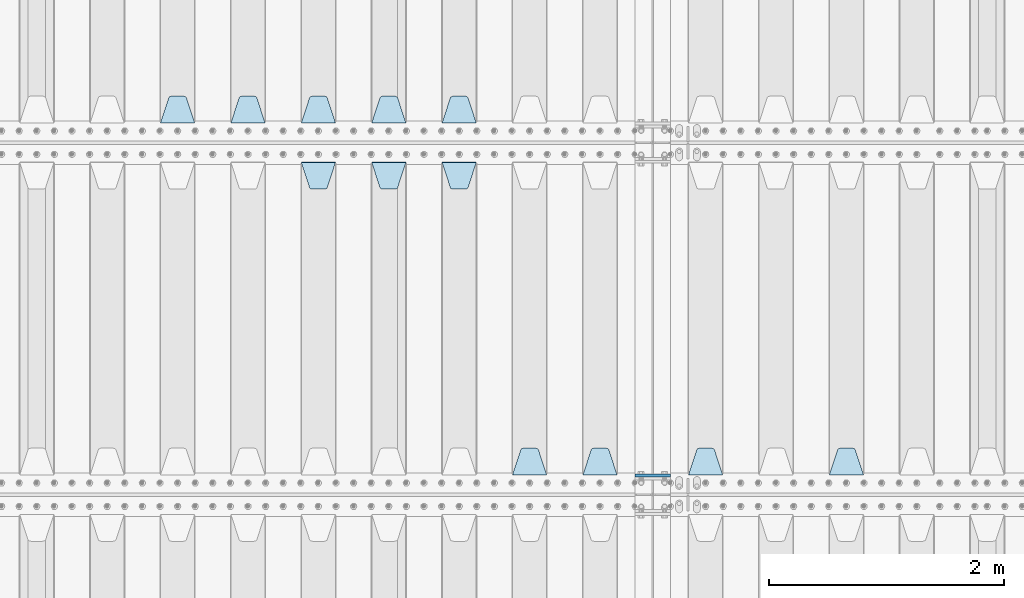
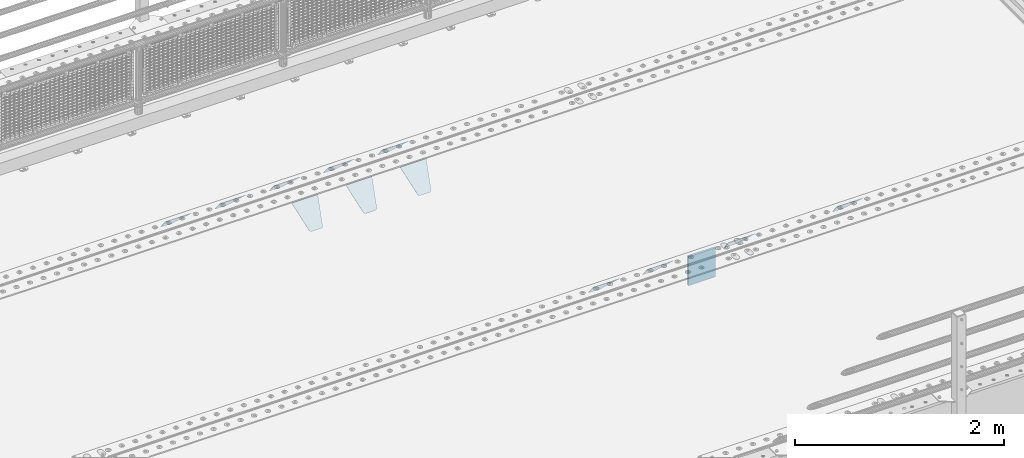
# One storey, part 209 of 247: 13 plates.
"""IFC2X3 building model written with IfcOpenShell, lengths in millimetres."""

from ifc_helpers import new_model, si_unit, frame, origin_with_axes, place, context, subcontext, project, spatial, faceted_brep, material, type_object, element, save


model = new_model("IFC2X3")

# Units and contexts
model_context = context("Model", 3, precision=1e-05, world=origin_with_axes())
body_context = subcontext(model_context, "Body", "Model", "MODEL_VIEW")
ifc_project = project(units=[si_unit("LENGTHUNIT", "METRE", prefix="MILLI"), si_unit("AREAUNIT", "SQUARE_METRE"), si_unit("VOLUMEUNIT", "CUBIC_METRE"), si_unit("MASSUNIT", "GRAM", prefix="KILO"), si_unit("TIMEUNIT", "SECOND"), si_unit("PLANEANGLEUNIT", "RADIAN"), si_unit("SOLIDANGLEUNIT", "STERADIAN"), si_unit("THERMODYNAMICTEMPERATUREUNIT", "DEGREE_CELSIUS"), si_unit("LUMINOUSINTENSITYUNIT", "LUMEN")], contexts=[model_context])

# Site, building, storey
site_placement = place(None, origin_with_axes())
site = spatial("IfcSite", under=ifc_project, at=site_placement, CompositionType="ELEMENT")
building_placement = place(site_placement, origin_with_axes())
building = spatial("IfcBuilding", under=site, at=building_placement, Name="Standard", CompositionType="ELEMENT")
storey_placement = place(building_placement, origin_with_axes())
storey = spatial("IfcBuildingStorey", under=building, at=storey_placement, Name="Undefined", CompositionType="ELEMENT", Elevation=0.0)

# Plates
ifc_material = material(Name="STEEL/S355N")
plate_type_1 = type_object("IfcPlateType", PredefinedType="NOTDEFINED")
plate_1_placement = place(storey_placement, frame((12100.0, 3162.5, -340.000000000044), z_axis=(0.0, 0.0, 1.0), x_axis=(1.0, 0.0, 0.0)))
element("IfcPlate", 1, at=plate_1_placement, inside=storey, type_object=plate_type_1, material=ifc_material, context=body_context, shape_type="Brep", body=[
    faceted_brep([(0.0, -12.5, 0.0), (0.0, -12.5, 340.0), (0.0, 12.5, 340.0), (0.0, 12.5, 0.0), (300.0, -12.5, 340.0), (300.0, 12.5, 340.0), (300.0, -12.5, 0.0), (300.0, 12.5, 0.0)], [[[0, 1, 2, 3]], [[1, 4, 5, 2]], [[4, 6, 7, 5]], [[6, 0, 3, 7]], [[5, 7, 3, 2]], [[6, 4, 1, 0]]]),
])
plate_type_2 = type_object("IfcPlateType", PredefinedType="NOTDEFINED")
plate_2_placement = place(storey_placement, frame((14045.0, 3168.23223304703, -1.76776695296758), z_axis=(0.0, 0.707106781186548, -0.707106781186547), x_axis=(-1.0, 0.0, 0.0)))
element("IfcPlate", 2, at=plate_2_placement, inside=storey, type_object=plate_type_2, material=ifc_material, context=body_context, shape_type="Brep", body=[
    faceted_brep([(0.0, -2.49999999999909, 0.0), (69.345504679477, -2.5, 300.17173142483), (69.345504679477, 2.50000000000091, 300.171731424831), (0.0, 2.5, -9.09494701772928e-13), (70.9274061199576, -2.5, 304.897442415399), (70.9274061199576, 2.50000000000091, 304.8974424154), (73.3818627772307, -2.49999999999909, 309.234538108527), (73.3818627772307, 2.5, 309.234538108526), (76.6187032999551, -2.5, 313.023683126102), (76.6187032999551, 2.50000000000091, 313.023683126102), (80.5190132704993, -2.49999999999909, 316.125672595371), (80.5190132704993, 2.50000000000091, 316.125672595372), (84.9395038596849, -2.49999999999909, 318.426546230476), (84.9395038596849, 2.5, 318.426546230475), (89.7177759439219, -2.5, 319.841774983274), (89.7177759439219, 2.50000000000091, 319.841774983275), (94.678286292652, -2.5, 320.319366455077), (94.678286292652, 2.50000000000091, 320.319366455077), (195.321713707348, -2.5, 320.319366455077), (195.321713707348, 2.50000000000091, 320.319366455077), (200.282224056078, -2.5, 319.841774983274), (200.282224056078, 2.50000000000091, 319.841774983275), (205.060496140315, -2.5, 318.426546230475), (205.060496140315, 2.5, 318.426546230474), (209.480986729501, -2.49999999999818, 316.12567259537), (209.480986729501, 2.50000000000091, 316.12567259537), (213.381296700045, -2.5, 313.023683126101), (213.381296700045, 2.50000000000091, 313.023683126101), (216.618137222769, -2.5, 309.234538108525), (216.618137222769, 2.5, 309.234538108525), (219.072593880042, -2.49999999999909, 304.897442415398), (219.072593880042, 2.5, 304.897442415398), (220.654495320523, -2.5, 300.17173142483), (220.654495320523, 2.50000000000091, 300.171731424831), (290.0, -2.49999999999909, 0.0), (290.0, 2.5, -9.09494701772928e-13)], [[[0, 1, 2, 3]], [[1, 4, 5, 2]], [[4, 6, 7, 5]], [[6, 8, 9, 7]], [[8, 10, 11, 9]], [[10, 12, 13, 11]], [[12, 14, 15, 13]], [[14, 16, 17, 15]], [[16, 18, 19, 17]], [[18, 20, 21, 19]], [[20, 22, 23, 21]], [[22, 24, 25, 23]], [[24, 26, 27, 25]], [[26, 28, 29, 27]], [[28, 30, 31, 29]], [[30, 32, 33, 31]], [[32, 34, 35, 33]], [[34, 0, 3, 35]], [[5, 7, 9, 11, 13, 15, 17, 19, 21, 23, 25, 27, 29, 31, 33, 35, 3, 2]], [[34, 32, 30, 28, 26, 24, 22, 20, 18, 16, 14, 12, 10, 8, 6, 4, 1, 0]]]),
])
plate_3_placement = place(storey_placement, frame((12845.0, 3168.23223304703, -1.76776695296758), z_axis=(0.0, 0.707106781186548, -0.707106781186547), x_axis=(-1.0, 0.0, 0.0)))
element("IfcPlate", 3, at=plate_3_placement, inside=storey, type_object=plate_type_2, material=ifc_material, context=body_context, shape_type="Brep", body=[
    faceted_brep([(0.0, -2.49999999999909, 0.0), (69.345504679477, -2.5, 300.17173142483), (69.345504679477, 2.50000000000091, 300.171731424831), (0.0, 2.5, -9.09494701772928e-13), (70.9274061199576, -2.5, 304.897442415399), (70.9274061199576, 2.50000000000091, 304.8974424154), (73.3818627772307, -2.49999999999909, 309.234538108527), (73.3818627772307, 2.5, 309.234538108526), (76.6187032999551, -2.5, 313.023683126102), (76.6187032999551, 2.50000000000091, 313.023683126102), (80.5190132704993, -2.49999999999909, 316.125672595371), (80.5190132704993, 2.50000000000091, 316.125672595372), (84.9395038596849, -2.49999999999909, 318.426546230476), (84.9395038596849, 2.5, 318.426546230475), (89.7177759439219, -2.5, 319.841774983274), (89.7177759439219, 2.50000000000091, 319.841774983275), (94.678286292652, -2.5, 320.319366455077), (94.678286292652, 2.50000000000091, 320.319366455077), (195.321713707348, -2.5, 320.319366455077), (195.321713707348, 2.50000000000091, 320.319366455077), (200.282224056078, -2.5, 319.841774983274), (200.282224056078, 2.50000000000091, 319.841774983275), (205.060496140315, -2.5, 318.426546230475), (205.060496140315, 2.5, 318.426546230474), (209.480986729501, -2.49999999999818, 316.12567259537), (209.480986729501, 2.50000000000091, 316.12567259537), (213.381296700045, -2.5, 313.023683126101), (213.381296700045, 2.50000000000091, 313.023683126101), (216.618137222769, -2.5, 309.234538108525), (216.618137222769, 2.5, 309.234538108525), (219.072593880042, -2.49999999999909, 304.897442415398), (219.072593880042, 2.5, 304.897442415398), (220.654495320523, -2.5, 300.17173142483), (220.654495320523, 2.50000000000091, 300.171731424831), (290.0, -2.49999999999909, 0.0), (290.0, 2.5, -9.09494701772928e-13)], [[[0, 1, 2, 3]], [[1, 4, 5, 2]], [[4, 6, 7, 5]], [[6, 8, 9, 7]], [[8, 10, 11, 9]], [[10, 12, 13, 11]], [[12, 14, 15, 13]], [[14, 16, 17, 15]], [[16, 18, 19, 17]], [[18, 20, 21, 19]], [[20, 22, 23, 21]], [[22, 24, 25, 23]], [[24, 26, 27, 25]], [[26, 28, 29, 27]], [[28, 30, 31, 29]], [[30, 32, 33, 31]], [[32, 34, 35, 33]], [[34, 0, 3, 35]], [[5, 7, 9, 11, 13, 15, 17, 19, 21, 23, 25, 27, 29, 31, 33, 35, 3, 2]], [[34, 32, 30, 28, 26, 24, 22, 20, 18, 16, 14, 12, 10, 8, 6, 4, 1, 0]]]),
])
plate_4_placement = place(storey_placement, frame((11945.0, 3168.23223304703, -1.76776695296758), z_axis=(0.0, 0.707106781186548, -0.707106781186547), x_axis=(-1.0, 0.0, 0.0)))
element("IfcPlate", 4, at=plate_4_placement, inside=storey, type_object=plate_type_2, material=ifc_material, context=body_context, shape_type="Brep", body=[
    faceted_brep([(0.0, -2.49999999999909, 0.0), (69.345504679477, -2.5, 300.17173142483), (69.345504679477, 2.50000000000091, 300.171731424831), (0.0, 2.5, -9.09494701772928e-13), (70.9274061199576, -2.5, 304.897442415399), (70.9274061199576, 2.50000000000091, 304.8974424154), (73.3818627772307, -2.49999999999909, 309.234538108527), (73.3818627772307, 2.5, 309.234538108526), (76.6187032999551, -2.5, 313.023683126102), (76.6187032999551, 2.50000000000091, 313.023683126102), (80.5190132704993, -2.49999999999909, 316.125672595371), (80.5190132704993, 2.50000000000091, 316.125672595372), (84.9395038596849, -2.49999999999909, 318.426546230476), (84.9395038596849, 2.5, 318.426546230475), (89.7177759439219, -2.5, 319.841774983274), (89.7177759439219, 2.50000000000091, 319.841774983275), (94.678286292652, -2.5, 320.319366455077), (94.678286292652, 2.50000000000091, 320.319366455077), (195.321713707348, -2.5, 320.319366455077), (195.321713707348, 2.50000000000091, 320.319366455077), (200.282224056078, -2.5, 319.841774983274), (200.282224056078, 2.50000000000091, 319.841774983275), (205.060496140315, -2.5, 318.426546230475), (205.060496140315, 2.5, 318.426546230474), (209.480986729501, -2.49999999999818, 316.12567259537), (209.480986729501, 2.50000000000091, 316.12567259537), (213.381296700045, -2.5, 313.023683126101), (213.381296700045, 2.50000000000091, 313.023683126101), (216.618137222769, -2.5, 309.234538108525), (216.618137222769, 2.5, 309.234538108525), (219.072593880042, -2.49999999999909, 304.897442415398), (219.072593880042, 2.5, 304.897442415398), (220.654495320523, -2.5, 300.17173142483), (220.654495320523, 2.50000000000091, 300.171731424831), (290.0, -2.49999999999909, 0.0), (290.0, 2.5, -9.09494701772928e-13)], [[[0, 1, 2, 3]], [[1, 4, 5, 2]], [[4, 6, 7, 5]], [[6, 8, 9, 7]], [[8, 10, 11, 9]], [[10, 12, 13, 11]], [[12, 14, 15, 13]], [[14, 16, 17, 15]], [[16, 18, 19, 17]], [[18, 20, 21, 19]], [[20, 22, 23, 21]], [[22, 24, 25, 23]], [[24, 26, 27, 25]], [[26, 28, 29, 27]], [[28, 30, 31, 29]], [[30, 32, 33, 31]], [[32, 34, 35, 33]], [[34, 0, 3, 35]], [[5, 7, 9, 11, 13, 15, 17, 19, 21, 23, 25, 27, 29, 31, 33, 35, 3, 2]], [[34, 32, 30, 28, 26, 24, 22, 20, 18, 16, 14, 12, 10, 8, 6, 4, 1, 0]]]),
])
plate_5_placement = place(storey_placement, frame((11345.0, 3168.23223304703, -1.76776695296758), z_axis=(0.0, 0.707106781186548, -0.707106781186547), x_axis=(-1.0, 0.0, 0.0)))
element("IfcPlate", 5, at=plate_5_placement, inside=storey, type_object=plate_type_2, material=ifc_material, context=body_context, shape_type="Brep", body=[
    faceted_brep([(0.0, -2.49999999999909, 0.0), (69.345504679477, -2.5, 300.17173142483), (69.345504679477, 2.50000000000091, 300.171731424831), (0.0, 2.5, -9.09494701772928e-13), (70.9274061199576, -2.5, 304.897442415399), (70.9274061199576, 2.50000000000091, 304.8974424154), (73.3818627772307, -2.49999999999909, 309.234538108527), (73.3818627772307, 2.5, 309.234538108526), (76.6187032999551, -2.5, 313.023683126102), (76.6187032999551, 2.50000000000091, 313.023683126102), (80.5190132704993, -2.49999999999909, 316.125672595371), (80.5190132704993, 2.50000000000091, 316.125672595372), (84.9395038596849, -2.49999999999909, 318.426546230476), (84.9395038596849, 2.5, 318.426546230475), (89.7177759439219, -2.5, 319.841774983274), (89.7177759439219, 2.50000000000091, 319.841774983275), (94.678286292652, -2.5, 320.319366455077), (94.678286292652, 2.50000000000091, 320.319366455077), (195.321713707348, -2.5, 320.319366455077), (195.321713707348, 2.50000000000091, 320.319366455077), (200.282224056078, -2.5, 319.841774983274), (200.282224056078, 2.50000000000091, 319.841774983275), (205.060496140315, -2.5, 318.426546230475), (205.060496140315, 2.5, 318.426546230474), (209.480986729501, -2.49999999999818, 316.12567259537), (209.480986729501, 2.50000000000091, 316.12567259537), (213.381296700045, -2.5, 313.023683126101), (213.381296700045, 2.50000000000091, 313.023683126101), (216.618137222769, -2.5, 309.234538108525), (216.618137222769, 2.5, 309.234538108525), (219.072593880042, -2.49999999999909, 304.897442415398), (219.072593880042, 2.5, 304.897442415398), (220.654495320523, -2.5, 300.17173142483), (220.654495320523, 2.50000000000091, 300.171731424831), (290.0, -2.49999999999909, 0.0), (290.0, 2.5, -9.09494701772928e-13)], [[[0, 1, 2, 3]], [[1, 4, 5, 2]], [[4, 6, 7, 5]], [[6, 8, 9, 7]], [[8, 10, 11, 9]], [[10, 12, 13, 11]], [[12, 14, 15, 13]], [[14, 16, 17, 15]], [[16, 18, 19, 17]], [[18, 20, 21, 19]], [[20, 22, 23, 21]], [[22, 24, 25, 23]], [[24, 26, 27, 25]], [[26, 28, 29, 27]], [[28, 30, 31, 29]], [[30, 32, 33, 31]], [[32, 34, 35, 33]], [[34, 0, 3, 35]], [[5, 7, 9, 11, 13, 15, 17, 19, 21, 23, 25, 27, 29, 31, 33, 35, 3, 2]], [[34, 32, 30, 28, 26, 24, 22, 20, 18, 16, 14, 12, 10, 8, 6, 4, 1, 0]]]),
])
plate_6_placement = place(storey_placement, frame((10455.0, 5831.76776695594, -1.767766952965), z_axis=(0.0, -0.707106781186548, -0.707106781186547), x_axis=(1.0, 0.0, 0.0)))
element("IfcPlate", 6, at=plate_6_placement, inside=storey, type_object=plate_type_2, material=ifc_material, context=body_context, shape_type="Brep", body=[
    faceted_brep([(0.0, -2.49999999999909, 0.0), (69.345504679477, -2.5, 300.17173142483), (69.345504679477, 2.50000000000091, 300.171731424831), (0.0, 2.5, -9.09494701772928e-13), (70.9274061199576, -2.5, 304.897442415399), (70.9274061199576, 2.50000000000091, 304.8974424154), (73.3818627772307, -2.49999999999909, 309.234538108527), (73.3818627772307, 2.5, 309.234538108526), (76.6187032999551, -2.5, 313.023683126102), (76.6187032999551, 2.50000000000091, 313.023683126102), (80.5190132704993, -2.49999999999909, 316.125672595371), (80.5190132704993, 2.50000000000091, 316.125672595372), (84.9395038596849, -2.49999999999909, 318.426546230476), (84.9395038596849, 2.5, 318.426546230475), (89.7177759439219, -2.5, 319.841774983274), (89.7177759439219, 2.50000000000091, 319.841774983275), (94.678286292652, -2.5, 320.319366455077), (94.678286292652, 2.50000000000091, 320.319366455077), (195.321713707348, -2.5, 320.319366455077), (195.321713707348, 2.50000000000091, 320.319366455077), (200.282224056078, -2.5, 319.841774983274), (200.282224056078, 2.50000000000091, 319.841774983275), (205.060496140315, -2.5, 318.426546230475), (205.060496140315, 2.5, 318.426546230474), (209.480986729501, -2.49999999999818, 316.12567259537), (209.480986729501, 2.50000000000091, 316.12567259537), (213.381296700045, -2.5, 313.023683126101), (213.381296700045, 2.50000000000091, 313.023683126101), (216.618137222769, -2.5, 309.234538108525), (216.618137222769, 2.5, 309.234538108525), (219.072593880042, -2.49999999999909, 304.897442415398), (219.072593880042, 2.5, 304.897442415398), (220.654495320523, -2.5, 300.17173142483), (220.654495320523, 2.50000000000091, 300.171731424831), (290.0, -2.49999999999909, 0.0), (290.0, 2.5, -9.09494701772928e-13)], [[[0, 1, 2, 3]], [[1, 4, 5, 2]], [[4, 6, 7, 5]], [[6, 8, 9, 7]], [[8, 10, 11, 9]], [[10, 12, 13, 11]], [[12, 14, 15, 13]], [[14, 16, 17, 15]], [[16, 18, 19, 17]], [[18, 20, 21, 19]], [[20, 22, 23, 21]], [[22, 24, 25, 23]], [[24, 26, 27, 25]], [[26, 28, 29, 27]], [[28, 30, 31, 29]], [[30, 32, 33, 31]], [[32, 34, 35, 33]], [[34, 0, 3, 35]], [[5, 7, 9, 11, 13, 15, 17, 19, 21, 23, 25, 27, 29, 31, 33, 35, 3, 2]], [[34, 32, 30, 28, 26, 24, 22, 20, 18, 16, 14, 12, 10, 8, 6, 4, 1, 0]]]),
])
plate_7_placement = place(storey_placement, frame((9855.0, 5831.76776695594, -1.767766952965), z_axis=(0.0, -0.707106781186548, -0.707106781186547), x_axis=(1.0, 0.0, 0.0)))
element("IfcPlate", 7, at=plate_7_placement, inside=storey, type_object=plate_type_2, material=ifc_material, context=body_context, shape_type="Brep", body=[
    faceted_brep([(0.0, -2.49999999999909, 0.0), (69.345504679477, -2.5, 300.17173142483), (69.345504679477, 2.50000000000091, 300.171731424831), (0.0, 2.5, -9.09494701772928e-13), (70.9274061199576, -2.5, 304.897442415399), (70.9274061199576, 2.50000000000091, 304.8974424154), (73.3818627772307, -2.49999999999909, 309.234538108527), (73.3818627772307, 2.5, 309.234538108526), (76.6187032999551, -2.5, 313.023683126102), (76.6187032999551, 2.50000000000091, 313.023683126102), (80.5190132704993, -2.49999999999909, 316.125672595371), (80.5190132704993, 2.50000000000091, 316.125672595372), (84.9395038596849, -2.49999999999909, 318.426546230476), (84.9395038596849, 2.5, 318.426546230475), (89.7177759439219, -2.5, 319.841774983274), (89.7177759439219, 2.50000000000091, 319.841774983275), (94.678286292652, -2.5, 320.319366455077), (94.678286292652, 2.50000000000091, 320.319366455077), (195.321713707348, -2.5, 320.319366455077), (195.321713707348, 2.50000000000091, 320.319366455077), (200.282224056078, -2.5, 319.841774983274), (200.282224056078, 2.50000000000091, 319.841774983275), (205.060496140315, -2.5, 318.426546230475), (205.060496140315, 2.5, 318.426546230474), (209.480986729501, -2.49999999999818, 316.12567259537), (209.480986729501, 2.50000000000091, 316.12567259537), (213.381296700045, -2.5, 313.023683126101), (213.381296700045, 2.50000000000091, 313.023683126101), (216.618137222769, -2.5, 309.234538108525), (216.618137222769, 2.5, 309.234538108525), (219.072593880042, -2.49999999999909, 304.897442415398), (219.072593880042, 2.5, 304.897442415398), (220.654495320523, -2.5, 300.17173142483), (220.654495320523, 2.50000000000091, 300.171731424831), (290.0, -2.49999999999909, 0.0), (290.0, 2.5, -9.09494701772928e-13)], [[[0, 1, 2, 3]], [[1, 4, 5, 2]], [[4, 6, 7, 5]], [[6, 8, 9, 7]], [[8, 10, 11, 9]], [[10, 12, 13, 11]], [[12, 14, 15, 13]], [[14, 16, 17, 15]], [[16, 18, 19, 17]], [[18, 20, 21, 19]], [[20, 22, 23, 21]], [[22, 24, 25, 23]], [[24, 26, 27, 25]], [[26, 28, 29, 27]], [[28, 30, 31, 29]], [[30, 32, 33, 31]], [[32, 34, 35, 33]], [[34, 0, 3, 35]], [[5, 7, 9, 11, 13, 15, 17, 19, 21, 23, 25, 27, 29, 31, 33, 35, 3, 2]], [[34, 32, 30, 28, 26, 24, 22, 20, 18, 16, 14, 12, 10, 8, 6, 4, 1, 0]]]),
])
plate_8_placement = place(storey_placement, frame((9255.0, 5831.76776695594, -1.767766952965), z_axis=(0.0, -0.707106781186548, -0.707106781186547), x_axis=(1.0, 0.0, 0.0)))
element("IfcPlate", 8, at=plate_8_placement, inside=storey, type_object=plate_type_2, material=ifc_material, context=body_context, shape_type="Brep", body=[
    faceted_brep([(0.0, -2.49999999999909, 0.0), (69.345504679477, -2.5, 300.17173142483), (69.345504679477, 2.50000000000091, 300.171731424831), (0.0, 2.5, -9.09494701772928e-13), (70.9274061199576, -2.5, 304.897442415399), (70.9274061199576, 2.50000000000091, 304.8974424154), (73.3818627772307, -2.49999999999909, 309.234538108527), (73.3818627772307, 2.5, 309.234538108526), (76.6187032999551, -2.5, 313.023683126102), (76.6187032999551, 2.50000000000091, 313.023683126102), (80.5190132704993, -2.49999999999909, 316.125672595371), (80.5190132704993, 2.50000000000091, 316.125672595372), (84.9395038596849, -2.49999999999909, 318.426546230476), (84.9395038596849, 2.5, 318.426546230475), (89.7177759439219, -2.5, 319.841774983274), (89.7177759439219, 2.50000000000091, 319.841774983275), (94.678286292652, -2.5, 320.319366455077), (94.678286292652, 2.50000000000091, 320.319366455077), (195.321713707348, -2.5, 320.319366455077), (195.321713707348, 2.50000000000091, 320.319366455077), (200.282224056078, -2.5, 319.841774983274), (200.282224056078, 2.50000000000091, 319.841774983275), (205.060496140315, -2.5, 318.426546230475), (205.060496140315, 2.5, 318.426546230474), (209.480986729501, -2.49999999999818, 316.12567259537), (209.480986729501, 2.50000000000091, 316.12567259537), (213.381296700045, -2.5, 313.023683126101), (213.381296700045, 2.50000000000091, 313.023683126101), (216.618137222769, -2.5, 309.234538108525), (216.618137222769, 2.5, 309.234538108525), (219.072593880042, -2.49999999999909, 304.897442415398), (219.072593880042, 2.5, 304.897442415398), (220.654495320523, -2.5, 300.17173142483), (220.654495320523, 2.50000000000091, 300.171731424831), (290.0, -2.49999999999909, 0.0), (290.0, 2.5, -9.09494701772928e-13)], [[[0, 1, 2, 3]], [[1, 4, 5, 2]], [[4, 6, 7, 5]], [[6, 8, 9, 7]], [[8, 10, 11, 9]], [[10, 12, 13, 11]], [[12, 14, 15, 13]], [[14, 16, 17, 15]], [[16, 18, 19, 17]], [[18, 20, 21, 19]], [[20, 22, 23, 21]], [[22, 24, 25, 23]], [[24, 26, 27, 25]], [[26, 28, 29, 27]], [[28, 30, 31, 29]], [[30, 32, 33, 31]], [[32, 34, 35, 33]], [[34, 0, 3, 35]], [[5, 7, 9, 11, 13, 15, 17, 19, 21, 23, 25, 27, 29, 31, 33, 35, 3, 2]], [[34, 32, 30, 28, 26, 24, 22, 20, 18, 16, 14, 12, 10, 8, 6, 4, 1, 0]]]),
])
plate_9_placement = place(storey_placement, frame((10745.0, 6168.23223304704, -1.76776695296758), z_axis=(0.0, 0.707106781186548, -0.707106781186547), x_axis=(-1.0, 0.0, 0.0)))
element("IfcPlate", 9, at=plate_9_placement, inside=storey, type_object=plate_type_2, material=ifc_material, context=body_context, shape_type="Brep", body=[
    faceted_brep([(0.0, -2.49999999999909, 0.0), (69.345504679477, -2.5, 300.17173142483), (69.345504679477, 2.50000000000091, 300.171731424831), (0.0, 2.5, -9.09494701772928e-13), (70.9274061199576, -2.5, 304.897442415399), (70.9274061199576, 2.50000000000091, 304.8974424154), (73.3818627772307, -2.49999999999909, 309.234538108527), (73.3818627772307, 2.5, 309.234538108526), (76.6187032999551, -2.5, 313.023683126102), (76.6187032999551, 2.50000000000091, 313.023683126102), (80.5190132704993, -2.49999999999909, 316.125672595371), (80.5190132704993, 2.50000000000091, 316.125672595372), (84.9395038596849, -2.49999999999909, 318.426546230476), (84.9395038596849, 2.5, 318.426546230475), (89.7177759439219, -2.5, 319.841774983274), (89.7177759439219, 2.50000000000091, 319.841774983275), (94.678286292652, -2.5, 320.319366455077), (94.678286292652, 2.50000000000091, 320.319366455077), (195.321713707348, -2.5, 320.319366455077), (195.321713707348, 2.50000000000091, 320.319366455077), (200.282224056078, -2.5, 319.841774983274), (200.282224056078, 2.50000000000091, 319.841774983275), (205.060496140315, -2.5, 318.426546230475), (205.060496140315, 2.5, 318.426546230474), (209.480986729501, -2.49999999999818, 316.12567259537), (209.480986729501, 2.50000000000091, 316.12567259537), (213.381296700045, -2.5, 313.023683126101), (213.381296700045, 2.50000000000091, 313.023683126101), (216.618137222769, -2.5, 309.234538108525), (216.618137222769, 2.5, 309.234538108525), (219.072593880042, -2.49999999999909, 304.897442415398), (219.072593880042, 2.5, 304.897442415398), (220.654495320523, -2.5, 300.17173142483), (220.654495320523, 2.50000000000091, 300.171731424831), (290.0, -2.49999999999909, 0.0), (290.0, 2.5, -9.09494701772928e-13)], [[[0, 1, 2, 3]], [[1, 4, 5, 2]], [[4, 6, 7, 5]], [[6, 8, 9, 7]], [[8, 10, 11, 9]], [[10, 12, 13, 11]], [[12, 14, 15, 13]], [[14, 16, 17, 15]], [[16, 18, 19, 17]], [[18, 20, 21, 19]], [[20, 22, 23, 21]], [[22, 24, 25, 23]], [[24, 26, 27, 25]], [[26, 28, 29, 27]], [[28, 30, 31, 29]], [[30, 32, 33, 31]], [[32, 34, 35, 33]], [[34, 0, 3, 35]], [[5, 7, 9, 11, 13, 15, 17, 19, 21, 23, 25, 27, 29, 31, 33, 35, 3, 2]], [[34, 32, 30, 28, 26, 24, 22, 20, 18, 16, 14, 12, 10, 8, 6, 4, 1, 0]]]),
])
plate_10_placement = place(storey_placement, frame((10145.0, 6168.23223304703, -1.76776695296758), z_axis=(0.0, 0.707106781186548, -0.707106781186547), x_axis=(-1.0, 0.0, 0.0)))
element("IfcPlate", 10, at=plate_10_placement, inside=storey, type_object=plate_type_2, material=ifc_material, context=body_context, shape_type="Brep", body=[
    faceted_brep([(0.0, -2.49999999999909, 0.0), (69.345504679477, -2.5, 300.17173142483), (69.345504679477, 2.50000000000091, 300.171731424831), (0.0, 2.5, -9.09494701772928e-13), (70.9274061199576, -2.5, 304.897442415399), (70.9274061199576, 2.50000000000091, 304.8974424154), (73.3818627772307, -2.49999999999909, 309.234538108527), (73.3818627772307, 2.5, 309.234538108526), (76.6187032999551, -2.5, 313.023683126102), (76.6187032999551, 2.50000000000091, 313.023683126102), (80.5190132704993, -2.49999999999909, 316.125672595371), (80.5190132704993, 2.50000000000091, 316.125672595372), (84.9395038596849, -2.49999999999909, 318.426546230476), (84.9395038596849, 2.5, 318.426546230475), (89.7177759439219, -2.5, 319.841774983274), (89.7177759439219, 2.50000000000091, 319.841774983275), (94.678286292652, -2.5, 320.319366455077), (94.678286292652, 2.50000000000091, 320.319366455077), (195.321713707348, -2.5, 320.319366455077), (195.321713707348, 2.50000000000091, 320.319366455077), (200.282224056078, -2.5, 319.841774983274), (200.282224056078, 2.50000000000091, 319.841774983275), (205.060496140315, -2.5, 318.426546230475), (205.060496140315, 2.5, 318.426546230474), (209.480986729501, -2.49999999999818, 316.12567259537), (209.480986729501, 2.50000000000091, 316.12567259537), (213.381296700045, -2.5, 313.023683126101), (213.381296700045, 2.50000000000091, 313.023683126101), (216.618137222769, -2.5, 309.234538108525), (216.618137222769, 2.5, 309.234538108525), (219.072593880042, -2.49999999999909, 304.897442415398), (219.072593880042, 2.5, 304.897442415398), (220.654495320523, -2.5, 300.17173142483), (220.654495320523, 2.50000000000091, 300.171731424831), (290.0, -2.49999999999909, 0.0), (290.0, 2.5, -9.09494701772928e-13)], [[[0, 1, 2, 3]], [[1, 4, 5, 2]], [[4, 6, 7, 5]], [[6, 8, 9, 7]], [[8, 10, 11, 9]], [[10, 12, 13, 11]], [[12, 14, 15, 13]], [[14, 16, 17, 15]], [[16, 18, 19, 17]], [[18, 20, 21, 19]], [[20, 22, 23, 21]], [[22, 24, 25, 23]], [[24, 26, 27, 25]], [[26, 28, 29, 27]], [[28, 30, 31, 29]], [[30, 32, 33, 31]], [[32, 34, 35, 33]], [[34, 0, 3, 35]], [[5, 7, 9, 11, 13, 15, 17, 19, 21, 23, 25, 27, 29, 31, 33, 35, 3, 2]], [[34, 32, 30, 28, 26, 24, 22, 20, 18, 16, 14, 12, 10, 8, 6, 4, 1, 0]]]),
])
plate_11_placement = place(storey_placement, frame((9545.0, 6168.23223304703, -1.76776695296758), z_axis=(0.0, 0.707106781186548, -0.707106781186547), x_axis=(-1.0, 0.0, 0.0)))
element("IfcPlate", 11, at=plate_11_placement, inside=storey, type_object=plate_type_2, material=ifc_material, context=body_context, shape_type="Brep", body=[
    faceted_brep([(0.0, -2.49999999999909, 0.0), (69.345504679477, -2.5, 300.17173142483), (69.345504679477, 2.50000000000091, 300.171731424831), (0.0, 2.5, -9.09494701772928e-13), (70.9274061199576, -2.5, 304.897442415399), (70.9274061199576, 2.50000000000091, 304.8974424154), (73.3818627772307, -2.49999999999909, 309.234538108527), (73.3818627772307, 2.5, 309.234538108526), (76.6187032999551, -2.5, 313.023683126102), (76.6187032999551, 2.50000000000091, 313.023683126102), (80.5190132704993, -2.49999999999909, 316.125672595371), (80.5190132704993, 2.50000000000091, 316.125672595372), (84.9395038596849, -2.49999999999909, 318.426546230476), (84.9395038596849, 2.5, 318.426546230475), (89.7177759439219, -2.5, 319.841774983274), (89.7177759439219, 2.50000000000091, 319.841774983275), (94.678286292652, -2.5, 320.319366455077), (94.678286292652, 2.50000000000091, 320.319366455077), (195.321713707348, -2.5, 320.319366455077), (195.321713707348, 2.50000000000091, 320.319366455077), (200.282224056078, -2.5, 319.841774983274), (200.282224056078, 2.50000000000091, 319.841774983275), (205.060496140315, -2.5, 318.426546230475), (205.060496140315, 2.5, 318.426546230474), (209.480986729501, -2.49999999999818, 316.12567259537), (209.480986729501, 2.50000000000091, 316.12567259537), (213.381296700045, -2.5, 313.023683126101), (213.381296700045, 2.50000000000091, 313.023683126101), (216.618137222769, -2.5, 309.234538108525), (216.618137222769, 2.5, 309.234538108525), (219.072593880042, -2.49999999999909, 304.897442415398), (219.072593880042, 2.5, 304.897442415398), (220.654495320523, -2.5, 300.17173142483), (220.654495320523, 2.50000000000091, 300.171731424831), (290.0, -2.49999999999909, 0.0), (290.0, 2.5, -9.09494701772928e-13)], [[[0, 1, 2, 3]], [[1, 4, 5, 2]], [[4, 6, 7, 5]], [[6, 8, 9, 7]], [[8, 10, 11, 9]], [[10, 12, 13, 11]], [[12, 14, 15, 13]], [[14, 16, 17, 15]], [[16, 18, 19, 17]], [[18, 20, 21, 19]], [[20, 22, 23, 21]], [[22, 24, 25, 23]], [[24, 26, 27, 25]], [[26, 28, 29, 27]], [[28, 30, 31, 29]], [[30, 32, 33, 31]], [[32, 34, 35, 33]], [[34, 0, 3, 35]], [[5, 7, 9, 11, 13, 15, 17, 19, 21, 23, 25, 27, 29, 31, 33, 35, 3, 2]], [[34, 32, 30, 28, 26, 24, 22, 20, 18, 16, 14, 12, 10, 8, 6, 4, 1, 0]]]),
])
plate_12_placement = place(storey_placement, frame((8945.0, 6168.23223304703, -1.76776695296758), z_axis=(0.0, 0.707106781186548, -0.707106781186547), x_axis=(-1.0, 0.0, 0.0)))
element("IfcPlate", 12, at=plate_12_placement, inside=storey, type_object=plate_type_2, material=ifc_material, context=body_context, shape_type="Brep", body=[
    faceted_brep([(0.0, -2.49999999999909, 0.0), (69.345504679477, -2.5, 300.17173142483), (69.345504679477, 2.50000000000091, 300.171731424831), (0.0, 2.5, -9.09494701772928e-13), (70.9274061199576, -2.5, 304.897442415399), (70.9274061199576, 2.50000000000091, 304.8974424154), (73.3818627772307, -2.49999999999909, 309.234538108527), (73.3818627772307, 2.5, 309.234538108526), (76.6187032999551, -2.5, 313.023683126102), (76.6187032999551, 2.50000000000091, 313.023683126102), (80.5190132704993, -2.49999999999909, 316.125672595371), (80.5190132704993, 2.50000000000091, 316.125672595372), (84.9395038596849, -2.49999999999909, 318.426546230476), (84.9395038596849, 2.5, 318.426546230475), (89.7177759439219, -2.5, 319.841774983274), (89.7177759439219, 2.50000000000091, 319.841774983275), (94.678286292652, -2.5, 320.319366455077), (94.678286292652, 2.50000000000091, 320.319366455077), (195.321713707348, -2.5, 320.319366455077), (195.321713707348, 2.50000000000091, 320.319366455077), (200.282224056078, -2.5, 319.841774983274), (200.282224056078, 2.50000000000091, 319.841774983275), (205.060496140315, -2.5, 318.426546230475), (205.060496140315, 2.5, 318.426546230474), (209.480986729501, -2.49999999999818, 316.12567259537), (209.480986729501, 2.50000000000091, 316.12567259537), (213.381296700045, -2.5, 313.023683126101), (213.381296700045, 2.50000000000091, 313.023683126101), (216.618137222769, -2.5, 309.234538108525), (216.618137222769, 2.5, 309.234538108525), (219.072593880042, -2.49999999999909, 304.897442415398), (219.072593880042, 2.5, 304.897442415398), (220.654495320523, -2.5, 300.17173142483), (220.654495320523, 2.50000000000091, 300.171731424831), (290.0, -2.49999999999909, 0.0), (290.0, 2.5, -9.09494701772928e-13)], [[[0, 1, 2, 3]], [[1, 4, 5, 2]], [[4, 6, 7, 5]], [[6, 8, 9, 7]], [[8, 10, 11, 9]], [[10, 12, 13, 11]], [[12, 14, 15, 13]], [[14, 16, 17, 15]], [[16, 18, 19, 17]], [[18, 20, 21, 19]], [[20, 22, 23, 21]], [[22, 24, 25, 23]], [[24, 26, 27, 25]], [[26, 28, 29, 27]], [[28, 30, 31, 29]], [[30, 32, 33, 31]], [[32, 34, 35, 33]], [[34, 0, 3, 35]], [[5, 7, 9, 11, 13, 15, 17, 19, 21, 23, 25, 27, 29, 31, 33, 35, 3, 2]], [[34, 32, 30, 28, 26, 24, 22, 20, 18, 16, 14, 12, 10, 8, 6, 4, 1, 0]]]),
])
plate_13_placement = place(storey_placement, frame((8345.0, 6168.23223304703, -1.76776695296758), z_axis=(0.0, 0.707106781186548, -0.707106781186547), x_axis=(-1.0, 0.0, 0.0)))
element("IfcPlate", 13, at=plate_13_placement, inside=storey, type_object=plate_type_2, material=ifc_material, context=body_context, shape_type="Brep", body=[
    faceted_brep([(0.0, -2.49999999999909, 0.0), (69.345504679477, -2.5, 300.17173142483), (69.345504679477, 2.50000000000091, 300.171731424831), (0.0, 2.5, -9.09494701772928e-13), (70.9274061199576, -2.5, 304.897442415399), (70.9274061199576, 2.50000000000091, 304.8974424154), (73.3818627772307, -2.49999999999909, 309.234538108527), (73.3818627772307, 2.5, 309.234538108526), (76.6187032999551, -2.5, 313.023683126102), (76.6187032999551, 2.50000000000091, 313.023683126102), (80.5190132704993, -2.49999999999909, 316.125672595371), (80.5190132704993, 2.50000000000091, 316.125672595372), (84.9395038596849, -2.49999999999909, 318.426546230476), (84.9395038596849, 2.5, 318.426546230475), (89.7177759439219, -2.5, 319.841774983274), (89.7177759439219, 2.50000000000091, 319.841774983275), (94.678286292652, -2.5, 320.319366455077), (94.678286292652, 2.50000000000091, 320.319366455077), (195.321713707348, -2.5, 320.319366455077), (195.321713707348, 2.50000000000091, 320.319366455077), (200.282224056078, -2.5, 319.841774983274), (200.282224056078, 2.50000000000091, 319.841774983275), (205.060496140315, -2.5, 318.426546230475), (205.060496140315, 2.5, 318.426546230474), (209.480986729501, -2.49999999999818, 316.12567259537), (209.480986729501, 2.50000000000091, 316.12567259537), (213.381296700045, -2.5, 313.023683126101), (213.381296700045, 2.50000000000091, 313.023683126101), (216.618137222769, -2.5, 309.234538108525), (216.618137222769, 2.5, 309.234538108525), (219.072593880042, -2.49999999999909, 304.897442415398), (219.072593880042, 2.5, 304.897442415398), (220.654495320523, -2.5, 300.17173142483), (220.654495320523, 2.50000000000091, 300.171731424831), (290.0, -2.49999999999909, 0.0), (290.0, 2.5, -9.09494701772928e-13)], [[[0, 1, 2, 3]], [[1, 4, 5, 2]], [[4, 6, 7, 5]], [[6, 8, 9, 7]], [[8, 10, 11, 9]], [[10, 12, 13, 11]], [[12, 14, 15, 13]], [[14, 16, 17, 15]], [[16, 18, 19, 17]], [[18, 20, 21, 19]], [[20, 22, 23, 21]], [[22, 24, 25, 23]], [[24, 26, 27, 25]], [[26, 28, 29, 27]], [[28, 30, 31, 29]], [[30, 32, 33, 31]], [[32, 34, 35, 33]], [[34, 0, 3, 35]], [[5, 7, 9, 11, 13, 15, 17, 19, 21, 23, 25, 27, 29, 31, 33, 35, 3, 2]], [[34, 32, 30, 28, 26, 24, 22, 20, 18, 16, 14, 12, 10, 8, 6, 4, 1, 0]]]),
])

save(model, "model.ifc")
